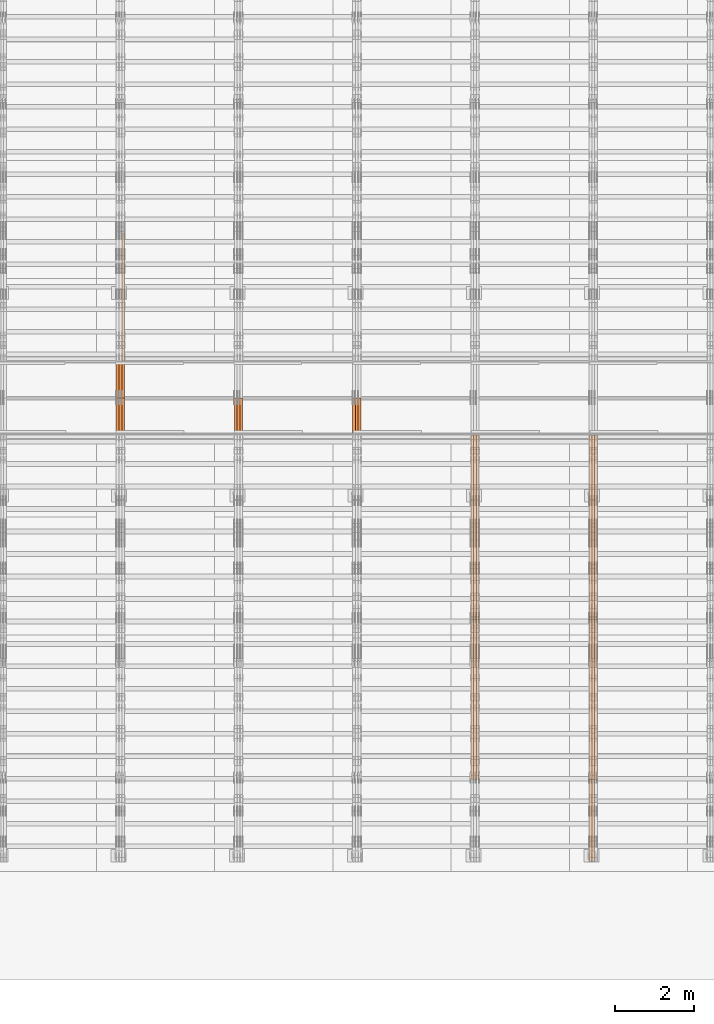
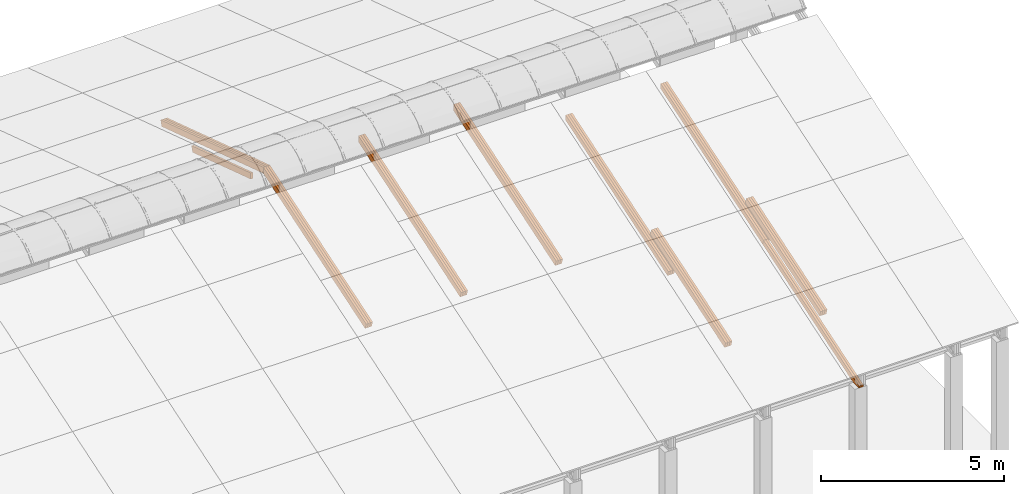
# One storey, part 26 of 385: 27 proxies.
"""IFC2X3 building model written with IfcOpenShell, lengths in millimetres."""

from ifc_helpers import new_model, entity, si_unit, converted_unit, derived_unit, direction, frame, origin, place, context, subcontext, project, spatial, polyline, outline, extrude, source, transform, mapped, material, type_object, type_shapes, element, save


model = new_model("IFC2X3")

# Units and contexts
model_context = context("Model", 3, precision=0.01, world=origin(), true_north=direction((6.12303176911189e-17, 1.0)))
body_context = subcontext(model_context, "Body", "Model", "MODEL_VIEW")
ifc_project = project(units=[si_unit("LENGTHUNIT", "METRE", prefix="MILLI"), si_unit("AREAUNIT", "SQUARE_METRE"), si_unit("VOLUMEUNIT", "CUBIC_METRE"), converted_unit("PLANEANGLEUNIT", "DEGREE", entity("IfcRatioMeasure", 0.0174532925199433), si_unit("PLANEANGLEUNIT", "RADIAN"), dimensions=[0, 0, 0, 0, 0, 0, 0]), si_unit("MASSUNIT", "GRAM", prefix="KILO"), derived_unit("MASSDENSITYUNIT", [(si_unit("MASSUNIT", "GRAM", prefix="KILO"), 1), (si_unit("LENGTHUNIT", "METRE"), -3)]), si_unit("TIMEUNIT", "SECOND"), si_unit("FREQUENCYUNIT", "HERTZ"), si_unit("THERMODYNAMICTEMPERATUREUNIT", "DEGREE_CELSIUS"), derived_unit("THERMALTRANSMITTANCEUNIT", [(si_unit("MASSUNIT", "GRAM", prefix="KILO"), 1), (si_unit("THERMODYNAMICTEMPERATUREUNIT", "KELVIN"), -1), (si_unit("TIMEUNIT", "SECOND"), -3)]), derived_unit("VOLUMETRICFLOWRATEUNIT", [(si_unit("LENGTHUNIT", "METRE"), 3), (si_unit("TIMEUNIT", "SECOND"), -1)]), si_unit("ELECTRICCURRENTUNIT", "AMPERE"), si_unit("ELECTRICVOLTAGEUNIT", "VOLT"), si_unit("POWERUNIT", "WATT"), si_unit("FORCEUNIT", "NEWTON", prefix="KILO"), si_unit("ILLUMINANCEUNIT", "LUX"), si_unit("LUMINOUSFLUXUNIT", "LUMEN"), si_unit("LUMINOUSINTENSITYUNIT", "CANDELA"), derived_unit("USERDEFINED", [(si_unit("MASSUNIT", "GRAM", prefix="KILO"), -1), (si_unit("LENGTHUNIT", "METRE"), -2), (si_unit("TIMEUNIT", "SECOND"), 3), (si_unit("LUMINOUSFLUXUNIT", "LUMEN"), 1)]), derived_unit("LINEARVELOCITYUNIT", [(si_unit("LENGTHUNIT", "METRE"), 1), (si_unit("TIMEUNIT", "SECOND"), -1)]), si_unit("PRESSUREUNIT", "PASCAL"), derived_unit("USERDEFINED", [(si_unit("LENGTHUNIT", "METRE"), -2), (si_unit("MASSUNIT", "GRAM", prefix="KILO"), 1), (si_unit("TIMEUNIT", "SECOND"), -2)])], contexts=[model_context])

# Site, building, storey
site_placement = place(None, origin())
site = spatial("IfcSite", under=ifc_project, at=site_placement, CompositionType="ELEMENT")
building_placement = place(site_placement, origin())
building = spatial("IfcBuilding", under=site, at=building_placement, CompositionType="ELEMENT")
storey_placement = place(building_placement, origin())
storey = spatial("IfcBuildingStorey", under=building, at=storey_placement, Name="Default", CompositionType="ELEMENT", Elevation=0.0)

# Proxies
ifc_material_1 = material(Name="IfcSurfaceStyle #524156")
building_element_proxy_type_1 = type_object("IfcBuildingElementProxyType", Name="T1-T2 524154", PredefinedType="NOTDEFINED", material=ifc_material_1)
shared_shape_1 = source(origin(), body_context, "Body", "SweptSolid", [
    extrude(outline(polyline([(-2137.04475371072, -97.5001541485635), (2137.04431231695, -97.5001541485635), (2137.0438249446, 97.5001541485636), (-2137.04338355082, 97.5001541485635), (-2137.04475371072, -97.5001541485635)])), frame((2137.04431231695, 97.5003268035489, 0.0), z_axis=(0.0, 0.0, 1.0), x_axis=(-1.0, 0.0, 0.0)), (0.0, 0.0, 1.0), 69.9999999999997),
])
type_shapes(building_element_proxy_type_1, [shared_shape_1])
proxy_1_placement = place(building_placement, frame((45385.0, 9160.11575124698, 2416.00267194857), z_axis=(-1.0, 0.0, 0.0), x_axis=(0.0, -0.951056516295154, -0.309016994374948)))
element("IfcBuildingElementProxy", 1, at=proxy_1_placement, inside=storey, type_object=building_element_proxy_type_1, material=ifc_material_1, Name="T1-T2", context=body_context, shape_type="MappedRepresentation", body=[
    mapped(shared_shape_1, transform((0.0, 0.0, 0.0), scale=1.0)),
])
ifc_material_2 = material(Name="IfcSurfaceStyle #524099")
building_element_proxy_type_2 = type_object("IfcBuildingElementProxyType", Name="T1-T2 524097", PredefinedType="NOTDEFINED", material=ifc_material_2)
shared_shape_2 = source(origin(), body_context, "Body", "SweptSolid", [
    extrude(outline(polyline([(-2137.04475371072, -97.5001541485635), (2137.04431231695, -97.5001541485635), (2137.0438249446, 97.5001541485636), (-2137.04338355082, 97.5001541485635), (-2137.04475371072, -97.5001541485635)])), frame((2137.04431231695, 97.5003268035489, 0.0), z_axis=(0.0, 0.0, 1.0), x_axis=(-1.0, 0.0, 0.0)), (0.0, 0.0, 1.0), 69.9999999999997),
])
type_shapes(building_element_proxy_type_2, [shared_shape_2])
proxy_2_placement = place(building_placement, frame((45315.0, 9160.11575124698, 2416.00267194857), z_axis=(-1.0, 0.0, 0.0), x_axis=(0.0, -0.951056516295154, -0.309016994374948)))
element("IfcBuildingElementProxy", 2, at=proxy_2_placement, inside=storey, type_object=building_element_proxy_type_2, material=ifc_material_2, Name="T1-T2", context=body_context, shape_type="MappedRepresentation", body=[
    mapped(shared_shape_2, transform((0.0, 0.0, 0.0), scale=1.0)),
])
ifc_material_3 = material(Name="IfcSurfaceStyle #524042")
building_element_proxy_type_3 = type_object("IfcBuildingElementProxyType", Name="T1-T2 524040", PredefinedType="NOTDEFINED", material=ifc_material_3)
shared_shape_3 = source(origin(), body_context, "Body", "SweptSolid", [
    extrude(outline(polyline([(-2137.04475371072, -97.5001541485635), (2137.04431231695, -97.5001541485635), (2137.0438249446, 97.5001541485636), (-2137.04338355082, 97.5001541485635), (-2137.04475371072, -97.5001541485635)])), frame((2137.04431231695, 97.5003268035489, 0.0), z_axis=(0.0, 0.0, 1.0), x_axis=(-1.0, 0.0, 0.0)), (0.0, 0.0, 1.0), 69.9999999999997),
])
type_shapes(building_element_proxy_type_3, [shared_shape_3])
proxy_3_placement = place(building_placement, frame((45245.0, 9160.11575124698, 2416.00267194857), z_axis=(-1.0, 0.0, 0.0), x_axis=(0.0, -0.951056516295154, -0.309016994374948)))
element("IfcBuildingElementProxy", 3, at=proxy_3_placement, inside=storey, type_object=building_element_proxy_type_3, material=ifc_material_3, Name="T1-T2", context=body_context, shape_type="MappedRepresentation", body=[
    mapped(shared_shape_3, transform((0.0, 0.0, 0.0), scale=1.0)),
])
ifc_material_4 = material(Name="IfcSurfaceStyle #523814")
building_element_proxy_type_4 = type_object("IfcBuildingElementProxyType", Name="T1-B4 523812", PredefinedType="NOTDEFINED", material=ifc_material_4)
shared_shape_4 = source(origin(), body_context, "Body", "SweptSolid", [
    extrude(outline(polyline([(-2912.13310129284, -85.0000958683222), (2939.75111293783, -85.0000958683222), (2939.75142473078, 85.0000958683222), (-2967.36943637577, 85.0000958683222), (-2912.13310129284, -85.0000958683222)])), frame((2939.75142473078, 85.0000958683222, 0.0), z_axis=(0.0, 0.0, 1.0), x_axis=(-1.0, 0.0, 0.0)), (0.0, 0.0, 1.0), 69.9999999999996),
])
type_shapes(building_element_proxy_type_4, [shared_shape_4])
proxy_4_placement = place(building_placement, frame((45385.0, 8161.99414062501, 1765.00476074219), z_axis=(-1.0, 0.0, 0.0), x_axis=(0.0, 0.951056516295124, 0.309016994375039)))
element("IfcBuildingElementProxy", 4, at=proxy_4_placement, inside=storey, type_object=building_element_proxy_type_4, material=ifc_material_4, Name="T1-B4", context=body_context, shape_type="MappedRepresentation", body=[
    mapped(shared_shape_4, transform((0.0, 0.0, 0.0), scale=1.0)),
])
ifc_material_5 = material(Name="IfcSurfaceStyle #523757")
building_element_proxy_type_5 = type_object("IfcBuildingElementProxyType", Name="T1-B4 523755", PredefinedType="NOTDEFINED", material=ifc_material_5)
shared_shape_5 = source(origin(), body_context, "Body", "SweptSolid", [
    extrude(outline(polyline([(-2912.13310129284, -85.0000958683222), (2939.75111293783, -85.0000958683222), (2939.75142473078, 85.0000958683222), (-2967.36943637577, 85.0000958683222), (-2912.13310129284, -85.0000958683222)])), frame((2939.75142473078, 85.0000958683222, 0.0), z_axis=(0.0, 0.0, 1.0), x_axis=(-1.0, 0.0, 0.0)), (0.0, 0.0, 1.0), 69.9999999999996),
])
type_shapes(building_element_proxy_type_5, [shared_shape_5])
proxy_5_placement = place(building_placement, frame((45315.0, 8161.99414062501, 1765.00476074219), z_axis=(-1.0, 0.0, 0.0), x_axis=(0.0, 0.951056516295124, 0.309016994375039)))
element("IfcBuildingElementProxy", 5, at=proxy_5_placement, inside=storey, type_object=building_element_proxy_type_5, material=ifc_material_5, Name="T1-B4", context=body_context, shape_type="MappedRepresentation", body=[
    mapped(shared_shape_5, transform((0.0, 0.0, 0.0), scale=1.0)),
])
ifc_material_6 = material(Name="IfcSurfaceStyle #523700")
building_element_proxy_type_6 = type_object("IfcBuildingElementProxyType", Name="T1-B4 523698", PredefinedType="NOTDEFINED", material=ifc_material_6)
shared_shape_6 = source(origin(), body_context, "Body", "SweptSolid", [
    extrude(outline(polyline([(-2912.13310129284, -85.0000958683222), (2939.75111293783, -85.0000958683222), (2939.75142473078, 85.0000958683222), (-2967.36943637577, 85.0000958683222), (-2912.13310129284, -85.0000958683222)])), frame((2939.75142473078, 85.0000958683222, 0.0), z_axis=(0.0, 0.0, 1.0), x_axis=(-1.0, 0.0, 0.0)), (0.0, 0.0, 1.0), 69.9999999999996),
])
type_shapes(building_element_proxy_type_6, [shared_shape_6])
proxy_6_placement = place(building_placement, frame((45245.0, 8161.99414062501, 1765.00476074219), z_axis=(-1.0, 0.0, 0.0), x_axis=(0.0, 0.951056516295124, 0.309016994375039)))
element("IfcBuildingElementProxy", 6, at=proxy_6_placement, inside=storey, type_object=building_element_proxy_type_6, material=ifc_material_6, Name="T1-B4", context=body_context, shape_type="MappedRepresentation", body=[
    mapped(shared_shape_6, transform((0.0, 0.0, 0.0), scale=1.0)),
])
ifc_material_7 = material(Name="IfcSurfaceStyle #523577")
building_element_proxy_type_7 = type_object("IfcBuildingElementProxyType", Name="T1-B5 523575", PredefinedType="NOTDEFINED", material=ifc_material_7)
shared_shape_7 = source(origin(), body_context, "Body", "SweptSolid", [
    extrude(outline(polyline([(-3238.20553797979, -89.0131148793731), (1950.26357999126, -89.0131148793731), (2273.6227955316, 16.0525968934038), (2252.52438864378, 80.9868164326712), (-3238.20522618685, 80.9868164326712), (-3238.20553797979, -89.0131148793731)])), frame((2273.6227955316, 80.9869419088758, 0.0), z_axis=(0.0, 0.0, 1.0), x_axis=(-1.0, 0.0, 0.0)), (0.0, 0.0, 1.0), 69.9999999999997),
])
type_shapes(building_element_proxy_type_7, [shared_shape_7])
proxy_7_placement = place(building_placement, frame((45315.0, 2919.93418387162, 61.7562319586341), z_axis=(-1.0, 0.0, 0.0), x_axis=(0.0, 0.951056516295124, 0.309016994375039)))
element("IfcBuildingElementProxy", 7, at=proxy_7_placement, inside=storey, type_object=building_element_proxy_type_7, material=ifc_material_7, Name="T1-B5", context=body_context, shape_type="MappedRepresentation", body=[
    mapped(shared_shape_7, transform((0.0, 0.0, 0.0), scale=1.0)),
])
ifc_material_8 = material(Name="IfcSurfaceStyle #523511")
building_element_proxy_type_8 = type_object("IfcBuildingElementProxyType", Name="T1-B5 523509", PredefinedType="NOTDEFINED", material=ifc_material_8)
shared_shape_8 = source(origin(), body_context, "Body", "SweptSolid", [
    extrude(outline(polyline([(-3238.20553797979, -89.0131148793731), (1950.26357999126, -89.0131148793731), (2273.6227955316, 16.0525968934038), (2252.52438864378, 80.9868164326712), (-3238.20522618685, 80.9868164326712), (-3238.20553797979, -89.0131148793731)])), frame((2273.6227955316, 80.9869419088758, 0.0), z_axis=(0.0, 0.0, 1.0), x_axis=(-1.0, 0.0, 0.0)), (0.0, 0.0, 1.0), 69.9999999999997),
])
type_shapes(building_element_proxy_type_8, [shared_shape_8])
proxy_8_placement = place(building_placement, frame((45245.0, 2919.93418387162, 61.7562319586341), z_axis=(-1.0, 0.0, 0.0), x_axis=(0.0, 0.951056516295124, 0.309016994375039)))
element("IfcBuildingElementProxy", 8, at=proxy_8_placement, inside=storey, type_object=building_element_proxy_type_8, material=ifc_material_8, Name="T1-B5", context=body_context, shape_type="MappedRepresentation", body=[
    mapped(shared_shape_8, transform((0.0, 0.0, 0.0), scale=1.0)),
])
ifc_material_9 = material(Name="IfcSurfaceStyle #489724")
building_element_proxy_type_9 = type_object("IfcBuildingElementProxyType", Name="T1-T2 489722", PredefinedType="NOTDEFINED", material=ifc_material_9)
shared_shape_9 = source(origin(), body_context, "Body", "SweptSolid", [
    extrude(outline(polyline([(-2137.04475371072, -97.5001541485635), (2137.04431231695, -97.5001541485635), (2137.0438249446, 97.5001541485636), (-2137.04338355082, 97.5001541485635), (-2137.04475371072, -97.5001541485635)])), frame((2137.04431231695, 97.5003268035489, 0.0), z_axis=(0.0, 0.0, 1.0), x_axis=(-1.0, 0.0, 0.0)), (0.0, 0.0, 1.0), 69.9999999999997),
])
type_shapes(building_element_proxy_type_9, [shared_shape_9])
proxy_9_placement = place(building_placement, frame((42385.0, 9160.11575124698, 2416.00267194857), z_axis=(-1.0, 0.0, 0.0), x_axis=(0.0, -0.951056516295154, -0.309016994374948)))
element("IfcBuildingElementProxy", 9, at=proxy_9_placement, inside=storey, type_object=building_element_proxy_type_9, material=ifc_material_9, Name="T1-T2", context=body_context, shape_type="MappedRepresentation", body=[
    mapped(shared_shape_9, transform((0.0, 0.0, 0.0), scale=1.0)),
])
ifc_material_10 = material(Name="IfcSurfaceStyle #489667")
building_element_proxy_type_10 = type_object("IfcBuildingElementProxyType", Name="T1-T2 489665", PredefinedType="NOTDEFINED", material=ifc_material_10)
shared_shape_10 = source(origin(), body_context, "Body", "SweptSolid", [
    extrude(outline(polyline([(-2137.04475371072, -97.5001541485635), (2137.04431231695, -97.5001541485635), (2137.0438249446, 97.5001541485636), (-2137.04338355082, 97.5001541485635), (-2137.04475371072, -97.5001541485635)])), frame((2137.04431231695, 97.5003268035489, 0.0), z_axis=(0.0, 0.0, 1.0), x_axis=(-1.0, 0.0, 0.0)), (0.0, 0.0, 1.0), 69.9999999999997),
])
type_shapes(building_element_proxy_type_10, [shared_shape_10])
proxy_10_placement = place(building_placement, frame((42315.0, 9160.11575124698, 2416.00267194857), z_axis=(-1.0, 0.0, 0.0), x_axis=(0.0, -0.951056516295154, -0.309016994374948)))
element("IfcBuildingElementProxy", 10, at=proxy_10_placement, inside=storey, type_object=building_element_proxy_type_10, material=ifc_material_10, Name="T1-T2", context=body_context, shape_type="MappedRepresentation", body=[
    mapped(shared_shape_10, transform((0.0, 0.0, 0.0), scale=1.0)),
])
ifc_material_11 = material(Name="IfcSurfaceStyle #489610")
building_element_proxy_type_11 = type_object("IfcBuildingElementProxyType", Name="T1-T2 489608", PredefinedType="NOTDEFINED", material=ifc_material_11)
shared_shape_11 = source(origin(), body_context, "Body", "SweptSolid", [
    extrude(outline(polyline([(-2137.04475371072, -97.5001541485635), (2137.04431231695, -97.5001541485635), (2137.0438249446, 97.5001541485636), (-2137.04338355082, 97.5001541485635), (-2137.04475371072, -97.5001541485635)])), frame((2137.04431231695, 97.5003268035489, 0.0), z_axis=(0.0, 0.0, 1.0), x_axis=(-1.0, 0.0, 0.0)), (0.0, 0.0, 1.0), 69.9999999999997),
])
type_shapes(building_element_proxy_type_11, [shared_shape_11])
proxy_11_placement = place(building_placement, frame((42245.0, 9160.11575124698, 2416.00267194857), z_axis=(-1.0, 0.0, 0.0), x_axis=(0.0, -0.951056516295154, -0.309016994374948)))
element("IfcBuildingElementProxy", 11, at=proxy_11_placement, inside=storey, type_object=building_element_proxy_type_11, material=ifc_material_11, Name="T1-T2", context=body_context, shape_type="MappedRepresentation", body=[
    mapped(shared_shape_11, transform((0.0, 0.0, 0.0), scale=1.0)),
])
ifc_material_12 = material(Name="IfcSurfaceStyle #489382")
building_element_proxy_type_12 = type_object("IfcBuildingElementProxyType", Name="T1-B4 489380", PredefinedType="NOTDEFINED", material=ifc_material_12)
shared_shape_12 = source(origin(), body_context, "Body", "SweptSolid", [
    extrude(outline(polyline([(-2912.13310129284, -85.0000958683222), (2939.75111293783, -85.0000958683222), (2939.75142473078, 85.0000958683222), (-2967.36943637577, 85.0000958683222), (-2912.13310129284, -85.0000958683222)])), frame((2939.75142473078, 85.0000958683222, 0.0), z_axis=(0.0, 0.0, 1.0), x_axis=(-1.0, 0.0, 0.0)), (0.0, 0.0, 1.0), 69.9999999999996),
])
type_shapes(building_element_proxy_type_12, [shared_shape_12])
proxy_12_placement = place(building_placement, frame((42385.0, 8161.994140625, 1765.00476074219), z_axis=(-1.0, 0.0, 0.0), x_axis=(0.0, 0.951056516295124, 0.309016994375039)))
element("IfcBuildingElementProxy", 12, at=proxy_12_placement, inside=storey, type_object=building_element_proxy_type_12, material=ifc_material_12, Name="T1-B4", context=body_context, shape_type="MappedRepresentation", body=[
    mapped(shared_shape_12, transform((0.0, 0.0, 0.0), scale=1.0)),
])
ifc_material_13 = material(Name="IfcSurfaceStyle #489325")
building_element_proxy_type_13 = type_object("IfcBuildingElementProxyType", Name="T1-B4 489323", PredefinedType="NOTDEFINED", material=ifc_material_13)
shared_shape_13 = source(origin(), body_context, "Body", "SweptSolid", [
    extrude(outline(polyline([(-2912.13310129284, -85.0000958683222), (2939.75111293783, -85.0000958683222), (2939.75142473078, 85.0000958683222), (-2967.36943637577, 85.0000958683222), (-2912.13310129284, -85.0000958683222)])), frame((2939.75142473078, 85.0000958683222, 0.0), z_axis=(0.0, 0.0, 1.0), x_axis=(-1.0, 0.0, 0.0)), (0.0, 0.0, 1.0), 69.9999999999996),
])
type_shapes(building_element_proxy_type_13, [shared_shape_13])
proxy_13_placement = place(building_placement, frame((42315.0, 8161.994140625, 1765.00476074219), z_axis=(-1.0, 0.0, 0.0), x_axis=(0.0, 0.951056516295124, 0.309016994375039)))
element("IfcBuildingElementProxy", 13, at=proxy_13_placement, inside=storey, type_object=building_element_proxy_type_13, material=ifc_material_13, Name="T1-B4", context=body_context, shape_type="MappedRepresentation", body=[
    mapped(shared_shape_13, transform((0.0, 0.0, 0.0), scale=1.0)),
])
ifc_material_14 = material(Name="IfcSurfaceStyle #489268")
building_element_proxy_type_14 = type_object("IfcBuildingElementProxyType", Name="T1-B4 489266", PredefinedType="NOTDEFINED", material=ifc_material_14)
shared_shape_14 = source(origin(), body_context, "Body", "SweptSolid", [
    extrude(outline(polyline([(-2912.13310129284, -85.0000958683222), (2939.75111293783, -85.0000958683222), (2939.75142473078, 85.0000958683222), (-2967.36943637577, 85.0000958683222), (-2912.13310129284, -85.0000958683222)])), frame((2939.75142473078, 85.0000958683222, 0.0), z_axis=(0.0, 0.0, 1.0), x_axis=(-1.0, 0.0, 0.0)), (0.0, 0.0, 1.0), 69.9999999999996),
])
type_shapes(building_element_proxy_type_14, [shared_shape_14])
proxy_14_placement = place(building_placement, frame((42245.0, 8161.994140625, 1765.00476074219), z_axis=(-1.0, 0.0, 0.0), x_axis=(0.0, 0.951056516295124, 0.309016994375039)))
element("IfcBuildingElementProxy", 14, at=proxy_14_placement, inside=storey, type_object=building_element_proxy_type_14, material=ifc_material_14, Name="T1-B4", context=body_context, shape_type="MappedRepresentation", body=[
    mapped(shared_shape_14, transform((0.0, 0.0, 0.0), scale=1.0)),
])
ifc_material_15 = material(Name="IfcSurfaceStyle #455121")
building_element_proxy_type_15 = type_object("IfcBuildingElementProxyType", Name="T1-T1 455119", PredefinedType="NOTDEFINED", material=ifc_material_15)
shared_shape_15 = source(origin(), body_context, "Body", "SweptSolid", [
    extrude(outline(polyline([(-2938.84391703088, -97.499801613968), (2970.52383457984, -97.499801613968), (2907.16448685427, 97.499801613968), (-2938.84440440323, 97.499801613968), (-2938.84391703088, -97.499801613968)])), frame((2970.52383457984, 97.5000757893295, 0.0), z_axis=(0.0, 0.0, 1.0), x_axis=(-1.0, 0.0, 0.0)), (0.0, 0.0, 1.0), 69.9999999999996),
])
type_shapes(building_element_proxy_type_15, [shared_shape_15])
proxy_15_placement = place(building_placement, frame((39385.0, 14780.2584052475, 4242.0978974122), z_axis=(-1.0, 0.0, 0.0), x_axis=(0.0, -0.951056516295154, -0.309016994374948)))
element("IfcBuildingElementProxy", 15, at=proxy_15_placement, inside=storey, type_object=building_element_proxy_type_15, material=ifc_material_15, Name="T1-T1", context=body_context, shape_type="MappedRepresentation", body=[
    mapped(shared_shape_15, transform((0.0, 0.0, 0.0), scale=1.0)),
])
ifc_material_16 = material(Name="IfcSurfaceStyle #455064")
building_element_proxy_type_16 = type_object("IfcBuildingElementProxyType", Name="T1-T1 455062", PredefinedType="NOTDEFINED", material=ifc_material_16)
shared_shape_16 = source(origin(), body_context, "Body", "SweptSolid", [
    extrude(outline(polyline([(-2938.84391703088, -97.499801613968), (2970.52383457984, -97.499801613968), (2907.16448685427, 97.499801613968), (-2938.84440440323, 97.499801613968), (-2938.84391703088, -97.499801613968)])), frame((2970.52383457984, 97.5000757893295, 0.0), z_axis=(0.0, 0.0, 1.0), x_axis=(-1.0, 0.0, 0.0)), (0.0, 0.0, 1.0), 69.9999999999996),
])
type_shapes(building_element_proxy_type_16, [shared_shape_16])
proxy_16_placement = place(building_placement, frame((39315.0, 14780.2584052475, 4242.0978974122), z_axis=(-1.0, 0.0, 0.0), x_axis=(0.0, -0.951056516295154, -0.309016994374948)))
element("IfcBuildingElementProxy", 16, at=proxy_16_placement, inside=storey, type_object=building_element_proxy_type_16, material=ifc_material_16, Name="T1-T1", context=body_context, shape_type="MappedRepresentation", body=[
    mapped(shared_shape_16, transform((0.0, 0.0, 0.0), scale=1.0)),
])
ifc_material_17 = material(Name="IfcSurfaceStyle #455007")
building_element_proxy_type_17 = type_object("IfcBuildingElementProxyType", Name="T1-T1 455005", PredefinedType="NOTDEFINED", material=ifc_material_17)
shared_shape_17 = source(origin(), body_context, "Body", "SweptSolid", [
    extrude(outline(polyline([(-2938.84391703088, -97.499801613968), (2970.52383457984, -97.499801613968), (2907.16448685427, 97.499801613968), (-2938.84440440323, 97.499801613968), (-2938.84391703088, -97.499801613968)])), frame((2970.52383457984, 97.5000757893295, 0.0), z_axis=(0.0, 0.0, 1.0), x_axis=(-1.0, 0.0, 0.0)), (0.0, 0.0, 1.0), 69.9999999999996),
])
type_shapes(building_element_proxy_type_17, [shared_shape_17])
proxy_17_placement = place(building_placement, frame((39245.0, 14780.2584052475, 4242.0978974122), z_axis=(-1.0, 0.0, 0.0), x_axis=(0.0, -0.951056516295154, -0.309016994374948)))
element("IfcBuildingElementProxy", 17, at=proxy_17_placement, inside=storey, type_object=building_element_proxy_type_17, material=ifc_material_17, Name="T1-T1", context=body_context, shape_type="MappedRepresentation", body=[
    mapped(shared_shape_17, transform((0.0, 0.0, 0.0), scale=1.0)),
])
ifc_material_18 = material(Name="IfcSurfaceStyle #420689")
building_element_proxy_type_18 = type_object("IfcBuildingElementProxyType", Name="T1-T1 420687", PredefinedType="NOTDEFINED", material=ifc_material_18)
shared_shape_18 = source(origin(), body_context, "Body", "SweptSolid", [
    extrude(outline(polyline([(-2938.84391703088, -97.499801613968), (2970.52383457984, -97.499801613968), (2907.16448685427, 97.499801613968), (-2938.84440440323, 97.499801613968), (-2938.84391703088, -97.499801613968)])), frame((2970.52383457984, 97.5000757893295, 0.0), z_axis=(0.0, 0.0, 1.0), x_axis=(-1.0, 0.0, 0.0)), (0.0, 0.0, 1.0), 69.9999999999996),
])
type_shapes(building_element_proxy_type_18, [shared_shape_18])
proxy_18_placement = place(building_placement, frame((36385.0, 14780.2584052475, 4242.0978974122), z_axis=(-1.0, 0.0, 0.0), x_axis=(0.0, -0.951056516295154, -0.309016994374948)))
element("IfcBuildingElementProxy", 18, at=proxy_18_placement, inside=storey, type_object=building_element_proxy_type_18, material=ifc_material_18, Name="T1-T1", context=body_context, shape_type="MappedRepresentation", body=[
    mapped(shared_shape_18, transform((0.0, 0.0, 0.0), scale=1.0)),
])
ifc_material_19 = material(Name="IfcSurfaceStyle #420632")
building_element_proxy_type_19 = type_object("IfcBuildingElementProxyType", Name="T1-T1 420630", PredefinedType="NOTDEFINED", material=ifc_material_19)
shared_shape_19 = source(origin(), body_context, "Body", "SweptSolid", [
    extrude(outline(polyline([(-2938.84391703088, -97.499801613968), (2970.52383457984, -97.499801613968), (2907.16448685427, 97.499801613968), (-2938.84440440323, 97.499801613968), (-2938.84391703088, -97.499801613968)])), frame((2970.52383457984, 97.5000757893295, 0.0), z_axis=(0.0, 0.0, 1.0), x_axis=(-1.0, 0.0, 0.0)), (0.0, 0.0, 1.0), 69.9999999999996),
])
type_shapes(building_element_proxy_type_19, [shared_shape_19])
proxy_19_placement = place(building_placement, frame((36315.0, 14780.2584052475, 4242.0978974122), z_axis=(-1.0, 0.0, 0.0), x_axis=(0.0, -0.951056516295154, -0.309016994374948)))
element("IfcBuildingElementProxy", 19, at=proxy_19_placement, inside=storey, type_object=building_element_proxy_type_19, material=ifc_material_19, Name="T1-T1", context=body_context, shape_type="MappedRepresentation", body=[
    mapped(shared_shape_19, transform((0.0, 0.0, 0.0), scale=1.0)),
])
ifc_material_20 = material(Name="IfcSurfaceStyle #420575")
building_element_proxy_type_20 = type_object("IfcBuildingElementProxyType", Name="T1-T1 420573", PredefinedType="NOTDEFINED", material=ifc_material_20)
shared_shape_20 = source(origin(), body_context, "Body", "SweptSolid", [
    extrude(outline(polyline([(-2938.84391703088, -97.499801613968), (2970.52383457984, -97.499801613968), (2907.16448685427, 97.499801613968), (-2938.84440440323, 97.499801613968), (-2938.84391703088, -97.499801613968)])), frame((2970.52383457984, 97.5000757893295, 0.0), z_axis=(0.0, 0.0, 1.0), x_axis=(-1.0, 0.0, 0.0)), (0.0, 0.0, 1.0), 69.9999999999996),
])
type_shapes(building_element_proxy_type_20, [shared_shape_20])
proxy_20_placement = place(building_placement, frame((36245.0, 14780.2584052475, 4242.0978974122), z_axis=(-1.0, 0.0, 0.0), x_axis=(0.0, -0.951056516295154, -0.309016994374948)))
element("IfcBuildingElementProxy", 20, at=proxy_20_placement, inside=storey, type_object=building_element_proxy_type_20, material=ifc_material_20, Name="T1-T1", context=body_context, shape_type="MappedRepresentation", body=[
    mapped(shared_shape_20, transform((0.0, 0.0, 0.0), scale=1.0)),
])
ifc_material_21 = material(Name="IfcSurfaceStyle #387112")
building_element_proxy_type_21 = type_object("IfcBuildingElementProxyType", Name="T1-T1 387110", PredefinedType="NOTDEFINED", material=ifc_material_21)
shared_shape_21 = source(origin(), body_context, "Body", "SweptSolid", [
    extrude(outline(polyline([(-2970.52406677137, -97.5001477982598), (2938.84461360547, -97.5001477982598), (2938.8441722117, 97.5001477982599), (-2907.1647190458, 97.5001477982598), (-2970.52406677137, -97.5001477982598)])), frame((2938.84461360547, 97.5001477982598, 0.0), z_axis=(0.0, 0.0, 1.0), x_axis=(-1.0, 0.0, 0.0)), (0.0, 0.0, 1.0), 69.9999999999996),
])
type_shapes(building_element_proxy_type_21, [shared_shape_21])
proxy_21_placement = place(building_placement, frame((33385.0, 20279.8851854154, 2416.0025491487), z_axis=(-1.0, 0.0, 0.0), x_axis=(0.0, -0.951056516295154, 0.309016994374948)))
element("IfcBuildingElementProxy", 21, at=proxy_21_placement, inside=storey, type_object=building_element_proxy_type_21, material=ifc_material_21, Name="T1-T1", context=body_context, shape_type="MappedRepresentation", body=[
    mapped(shared_shape_21, transform((0.0, 0.0, 0.0), scale=1.0)),
])
ifc_material_22 = material(Name="IfcSurfaceStyle #387055")
building_element_proxy_type_22 = type_object("IfcBuildingElementProxyType", Name="T1-T1 387053", PredefinedType="NOTDEFINED", material=ifc_material_22)
shared_shape_22 = source(origin(), body_context, "Body", "SweptSolid", [
    extrude(outline(polyline([(-2970.52406677137, -97.5001477982598), (2938.84461360547, -97.5001477982598), (2938.8441722117, 97.5001477982599), (-2907.1647190458, 97.5001477982598), (-2970.52406677137, -97.5001477982598)])), frame((2938.84461360547, 97.5001477982598, 0.0), z_axis=(0.0, 0.0, 1.0), x_axis=(-1.0, 0.0, 0.0)), (0.0, 0.0, 1.0), 69.9999999999996),
])
type_shapes(building_element_proxy_type_22, [shared_shape_22])
proxy_22_placement = place(building_placement, frame((33315.0, 20279.8851854154, 2416.0025491487), z_axis=(-1.0, 0.0, 0.0), x_axis=(0.0, -0.951056516295154, 0.309016994374948)))
element("IfcBuildingElementProxy", 22, at=proxy_22_placement, inside=storey, type_object=building_element_proxy_type_22, material=ifc_material_22, Name="T1-T1", context=body_context, shape_type="MappedRepresentation", body=[
    mapped(shared_shape_22, transform((0.0, 0.0, 0.0), scale=1.0)),
])
ifc_material_23 = material(Name="IfcSurfaceStyle #386998")
building_element_proxy_type_23 = type_object("IfcBuildingElementProxyType", Name="T1-T1 386996", PredefinedType="NOTDEFINED", material=ifc_material_23)
shared_shape_23 = source(origin(), body_context, "Body", "SweptSolid", [
    extrude(outline(polyline([(-2970.52406677137, -97.5001477982598), (2938.84461360547, -97.5001477982598), (2938.8441722117, 97.5001477982599), (-2907.1647190458, 97.5001477982598), (-2970.52406677137, -97.5001477982598)])), frame((2938.84461360547, 97.5001477982598, 0.0), z_axis=(0.0, 0.0, 1.0), x_axis=(-1.0, 0.0, 0.0)), (0.0, 0.0, 1.0), 69.9999999999996),
])
type_shapes(building_element_proxy_type_23, [shared_shape_23])
proxy_23_placement = place(building_placement, frame((33245.0, 20279.8851854154, 2416.0025491487), z_axis=(-1.0, 0.0, 0.0), x_axis=(0.0, -0.951056516295154, 0.309016994374948)))
element("IfcBuildingElementProxy", 23, at=proxy_23_placement, inside=storey, type_object=building_element_proxy_type_23, material=ifc_material_23, Name="T1-T1", context=body_context, shape_type="MappedRepresentation", body=[
    mapped(shared_shape_23, transform((0.0, 0.0, 0.0), scale=1.0)),
])
ifc_material_24 = material(Name="IfcSurfaceStyle #386257")
building_element_proxy_type_24 = type_object("IfcBuildingElementProxyType", Name="T1-T1 386255", PredefinedType="NOTDEFINED", material=ifc_material_24)
shared_shape_24 = source(origin(), body_context, "Body", "SweptSolid", [
    extrude(outline(polyline([(-2938.84391703088, -97.499801613968), (2970.52383457984, -97.499801613968), (2907.16448685427, 97.499801613968), (-2938.84440440323, 97.499801613968), (-2938.84391703088, -97.499801613968)])), frame((2970.52383457984, 97.5000757893295, 0.0), z_axis=(0.0, 0.0, 1.0), x_axis=(-1.0, 0.0, 0.0)), (0.0, 0.0, 1.0), 69.9999999999996),
])
type_shapes(building_element_proxy_type_24, [shared_shape_24])
proxy_24_placement = place(building_placement, frame((33385.0, 14780.2584052475, 4242.0978974122), z_axis=(-1.0, 0.0, 0.0), x_axis=(0.0, -0.951056516295154, -0.309016994374948)))
element("IfcBuildingElementProxy", 24, at=proxy_24_placement, inside=storey, type_object=building_element_proxy_type_24, material=ifc_material_24, Name="T1-T1", context=body_context, shape_type="MappedRepresentation", body=[
    mapped(shared_shape_24, transform((0.0, 0.0, 0.0), scale=1.0)),
])
ifc_material_25 = material(Name="IfcSurfaceStyle #386200")
building_element_proxy_type_25 = type_object("IfcBuildingElementProxyType", Name="T1-T1 386198", PredefinedType="NOTDEFINED", material=ifc_material_25)
shared_shape_25 = source(origin(), body_context, "Body", "SweptSolid", [
    extrude(outline(polyline([(-2938.84391703088, -97.499801613968), (2970.52383457984, -97.499801613968), (2907.16448685427, 97.499801613968), (-2938.84440440323, 97.499801613968), (-2938.84391703088, -97.499801613968)])), frame((2970.52383457984, 97.5000757893295, 0.0), z_axis=(0.0, 0.0, 1.0), x_axis=(-1.0, 0.0, 0.0)), (0.0, 0.0, 1.0), 69.9999999999996),
])
type_shapes(building_element_proxy_type_25, [shared_shape_25])
proxy_25_placement = place(building_placement, frame((33315.0, 14780.2584052475, 4242.0978974122), z_axis=(-1.0, 0.0, 0.0), x_axis=(0.0, -0.951056516295154, -0.309016994374948)))
element("IfcBuildingElementProxy", 25, at=proxy_25_placement, inside=storey, type_object=building_element_proxy_type_25, material=ifc_material_25, Name="T1-T1", context=body_context, shape_type="MappedRepresentation", body=[
    mapped(shared_shape_25, transform((0.0, 0.0, 0.0), scale=1.0)),
])
ifc_material_26 = material(Name="IfcSurfaceStyle #386143")
building_element_proxy_type_26 = type_object("IfcBuildingElementProxyType", Name="T1-T1 386141", PredefinedType="NOTDEFINED", material=ifc_material_26)
shared_shape_26 = source(origin(), body_context, "Body", "SweptSolid", [
    extrude(outline(polyline([(-2938.84391703088, -97.499801613968), (2970.52383457984, -97.499801613968), (2907.16448685427, 97.499801613968), (-2938.84440440323, 97.499801613968), (-2938.84391703088, -97.499801613968)])), frame((2970.52383457984, 97.5000757893295, 0.0), z_axis=(0.0, 0.0, 1.0), x_axis=(-1.0, 0.0, 0.0)), (0.0, 0.0, 1.0), 69.9999999999996),
])
type_shapes(building_element_proxy_type_26, [shared_shape_26])
proxy_26_placement = place(building_placement, frame((33245.0, 14780.2584052475, 4242.0978974122), z_axis=(-1.0, 0.0, 0.0), x_axis=(0.0, -0.951056516295154, -0.309016994374948)))
element("IfcBuildingElementProxy", 26, at=proxy_26_placement, inside=storey, type_object=building_element_proxy_type_26, material=ifc_material_26, Name="T1-T1", context=body_context, shape_type="MappedRepresentation", body=[
    mapped(shared_shape_26, transform((0.0, 0.0, 0.0), scale=1.0)),
])
ifc_material_27 = material(Name="IfcSurfaceStyle #385717")
building_element_proxy_type_27 = type_object("IfcBuildingElementProxyType", Name="T1-B3 385715", PredefinedType="NOTDEFINED", material=ifc_material_27)
shared_shape_27 = source(origin(), body_context, "Body", "SweptSolid", [
    extrude(outline(polyline([(-1715.8757175801, -97.4999653079672), (1684.19580003112, -97.4999653079672), (1684.19628740349, 97.4999653079672), (-1652.51636985451, 97.4999653079672), (-1715.8757175801, -97.4999653079672)])), frame((1684.19628740349, 97.5000561131842, 0.0), z_axis=(0.0, 0.0, 1.0), x_axis=(-1.0, 0.0, 0.0)), (0.0, 0.0, 1.0), 69.9999999999998),
])
type_shapes(building_element_proxy_type_27, [shared_shape_27])
proxy_27_placement = place(building_placement, frame((33385.0, 18833.4023156896, 2380.55582184223), z_axis=(-1.0, 0.0, 0.0), x_axis=(0.0, -0.951056516295124, 0.309016994375039)))
element("IfcBuildingElementProxy", 27, at=proxy_27_placement, inside=storey, type_object=building_element_proxy_type_27, material=ifc_material_27, Name="T1-B3", context=body_context, shape_type="MappedRepresentation", body=[
    mapped(shared_shape_27, transform((0.0, 0.0, 0.0), scale=1.0)),
])

save(model, "model.ifc")
